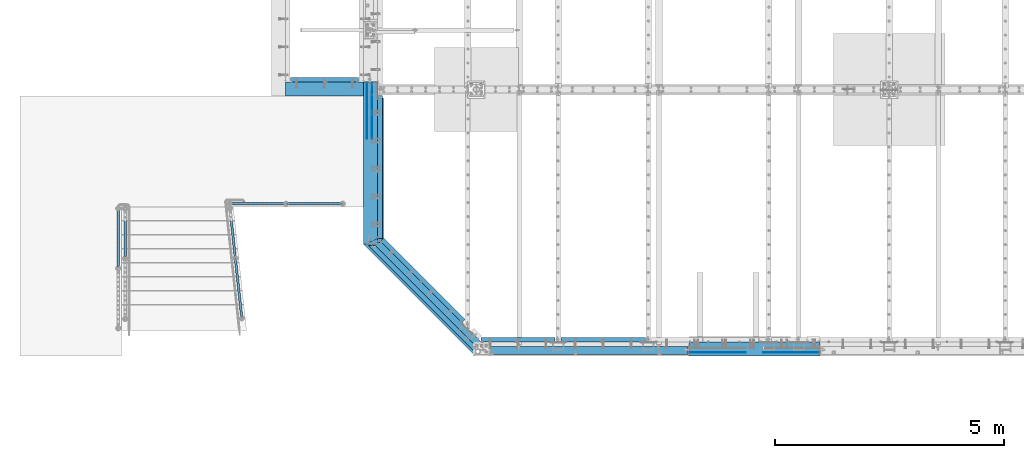
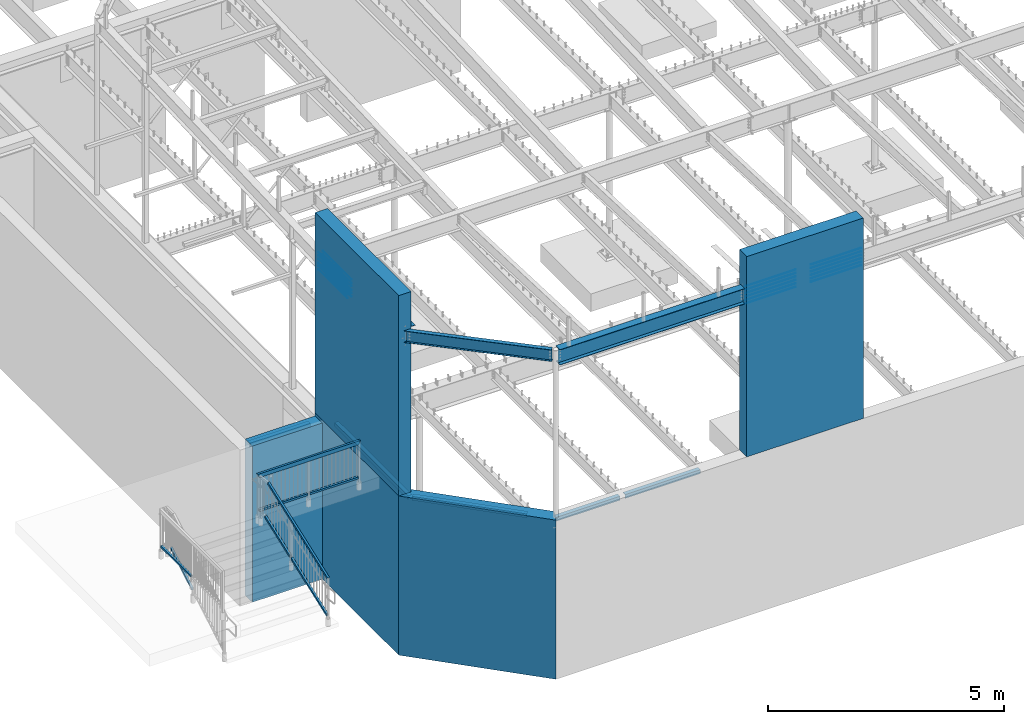
# One storey, part 309 of 975: 41 beams, 4 members.
"""IFC2X3 building model written with IfcOpenShell, lengths in millimetres."""

from ifc_helpers import new_model, si_unit, frame, origin_with_axes, place, context, subcontext, project, spatial, faceted_brep, material, type_object, element, save


model = new_model("IFC2X3")

# Units and contexts
model_context = context("Model", 3, precision=1e-05, world=origin_with_axes())
body_context = subcontext(model_context, "Body", "Model", "MODEL_VIEW")
ifc_project = project(units=[si_unit("LENGTHUNIT", "METRE", prefix="MILLI"), si_unit("AREAUNIT", "SQUARE_METRE"), si_unit("VOLUMEUNIT", "CUBIC_METRE"), si_unit("MASSUNIT", "GRAM", prefix="KILO"), si_unit("TIMEUNIT", "SECOND"), si_unit("PLANEANGLEUNIT", "RADIAN"), si_unit("SOLIDANGLEUNIT", "STERADIAN"), si_unit("THERMODYNAMICTEMPERATUREUNIT", "DEGREE_CELSIUS"), si_unit("LUMINOUSINTENSITYUNIT", "LUMEN")], contexts=[model_context])

# Site, building, storey
site_placement = place(None, origin_with_axes())
site = spatial("IfcSite", under=ifc_project, at=site_placement, CompositionType="ELEMENT")
building_placement = place(site_placement, origin_with_axes())
building = spatial("IfcBuilding", under=site, at=building_placement, Name="Undefined", CompositionType="ELEMENT")
storey_placement = place(building_placement, origin_with_axes())
storey = spatial("IfcBuildingStorey", under=building, at=storey_placement, Name="Undefined", CompositionType="ELEMENT", Elevation=0.0)

# Beams
ifc_material_1 = material()
beam_type_1 = type_object("IfcBeamType", Name="HSS2X2X.188_TUBES", PredefinedType="NOTDEFINED")
beam_1_placement = place(storey_placement, frame((479.425390027596, 3327.40039056696, 4229.10001248399), z_axis=(-3.3379000014861e-05, 0.999999999442921, 0.0), x_axis=(0.999999999442921, 3.33790000148717e-05, -8.99999974375122e-09)))
element("IfcBeam", 1, at=beam_1_placement, inside=storey, type_object=beam_type_1, material=ifc_material_1, Name="HANDRAIL", ObjectType="HSS2X2X.188_TUBES", context=body_context, shape_type="Brep", body=[
    faceted_brep([(-131.330281743522, 20.6374999999525, -20.6374999999862), (-131.330282156286, -20.637500000048, -20.6374999999798), (1054.09891845322, -20.6374999996206, -20.6375000001312), (1054.09891886599, 20.6375000003791, -20.6375000001376), (-131.328904438064, -20.6375000000471, 20.6375000000207), (1054.10029617145, -20.6374999996215, 20.6374999998693), (-131.3289040253, 20.6374999999525, 20.6375000000144), (1054.10029658421, 20.6375000003791, 20.6374999998629), (-131.330440663382, 25.3999999999523, -25.3999999999869), (-131.328745010186, 25.3999999999523, 25.4000000000137), (1054.10045559932, 25.4000000003798, 25.3999999998628), (1054.09875994613, 25.4000000003798, -25.4000000001379), (-131.328745518203, -25.4000000000478, 25.4000000000215), (1054.10045509131, -25.3999999996204, 25.3999999998705), (-131.330441171399, -25.4000000000469, -25.3999999999796), (1054.09875943811, -25.3999999996204, -25.4000000001297)], [[[0, 1, 2, 3]], [[1, 4, 5, 2]], [[4, 6, 7, 5]], [[6, 0, 3, 7]], [[8, 9, 10, 11]], [[9, 12, 13, 10]], [[12, 14, 15, 13]], [[14, 8, 11, 15]], [[13, 15, 11, 10], [5, 7, 3, 2]], [[14, 12, 9, 8], [6, 4, 1, 0]]]),
])
beam_2_placement = place(storey_placement, frame((-913.533792306628, 3327.43681280912, 4229.10002239251), z_axis=(2.61469999909423e-05, 0.999999999658167, 0.0), x_axis=(0.999999999658167, -2.61469999909112e-05, -7.00000017624839e-09)))
element("IfcBeam", 2, at=beam_2_placement, inside=storey, type_object=beam_type_1, material=ifc_material_1, Name="HANDRAIL", ObjectType="HSS2X2X.188_TUBES", context=body_context, shape_type="Brep", body=[
    faceted_brep([(25.400897527059, 20.6375000000089, -20.6374999999903), (25.4009170500576, -20.6374999999916, -20.637499999993), (1210.83012917405, -20.6374999995396, -20.6374999999694), (1210.83012950426, 20.6375000004609, -20.6374999999771), (25.3998894558863, -20.6375000000044, 20.6375), (1210.82904995662, -20.6374999995396, 20.6375000000248), (25.3998247226641, 20.6375000000016, 20.6374999999316), (1210.82905028684, 20.63750000046, 20.6375000000171), (25.4010547061143, 25.4000000000133, -25.400000000096), (25.3997254455859, 25.4000000000096, 25.3999999999928), (1210.82892579985, 25.4000000004608, 25.400000000016), (1210.83025406745, 25.4000000004608, -25.3999999999769), (25.3997250391686, -25.3999999999905, 25.4000000000019), (1210.82892539343, -25.3999999995394, 25.4000000000251), (25.4010533067686, -25.3999999999896, -25.399999999991), (1210.83025366103, -25.3999999995394, -25.3999999999678)], [[[0, 1, 2, 3]], [[1, 4, 5, 2]], [[4, 6, 7, 5]], [[6, 0, 3, 7]], [[8, 9, 10, 11]], [[9, 12, 13, 10]], [[12, 14, 15, 13]], [[14, 8, 11, 15]], [[13, 15, 11, 10], [5, 7, 3, 2]], [[14, 12, 9, 8], [6, 4, 1, 0]]]),
])
beam_3_placement = place(storey_placement, frame((-3343.27499858123, 1917.70035219894, 4229.10001248399), z_axis=(-0.999999999999998, 6.90000001668524e-08, 0.0), x_axis=(0.0, 1.0, 0.0)))
element("IfcBeam", 3, at=beam_3_placement, inside=storey, type_object=beam_type_1, material=ifc_material_1, Name="HANDRAIL", ObjectType="HSS2X2X.188_TUBES", context=body_context, shape_type="Brep", body=[
    faceted_brep([(25.3999997357314, 20.6374999999898, -20.6374999999998), (25.4000002641624, -20.6375000000153, -20.6374999999998), (1282.70000035021, -20.637500000109, -20.6374999999998), (1282.70000072169, 20.6374999998907, -20.6374999999998), (25.4000002641624, -20.6375000000153, 20.6374999999998), (1282.70000035021, -20.637500000109, 20.6374999999998), (25.3999997357314, 20.6374999999898, 20.6374999999998), (1282.70000072169, 20.6374999998907, 20.6374999999998), (25.4000003077635, 25.3999999999942, -25.3999999999996), (25.3999996747552, 25.3999999999905, 25.3999999999996), (1282.70000076455, 25.3999999998914, 25.4000000000001), (1282.70000076455, 25.3999999998914, -25.4000000000001), (25.4000003251349, -25.4000000000124, 25.3999999999996), (1282.70000030735, -25.4000000001088, 25.4000000000001), (25.4000003077854, -25.4000000000087, -25.3999999999996), (1282.70000030735, -25.4000000001088, -25.4000000000001)], [[[0, 1, 2, 3]], [[1, 4, 5, 2]], [[4, 6, 7, 5]], [[6, 0, 3, 7]], [[8, 9, 10, 11]], [[9, 12, 13, 10]], [[12, 14, 15, 13]], [[14, 8, 11, 15]], [[13, 15, 11, 10], [5, 7, 3, 2]], [[14, 12, 9, 8], [6, 4, 1, 0]]]),
])

# Members
member_type = type_object("IfcMemberType", Name="HSS2X2X.188_TUBES", PredefinedType="NOTDEFINED")
member_1_placement = place(storey_placement, frame((-786.90592702159, 2152.61454383, 3699.25226004186), z_axis=(-0.99424137783609, -0.107163811982336, -8.59999973377852e-08), x_axis=(-0.0925657529716952, 0.858804733737394, 0.503871025845926)))
element("IfcMember", 4, at=member_1_placement, inside=storey, type_object=member_type, material=ifc_material_1, Name="HANDRAIL", ObjectType="HSS2X2X.188_TUBES", context=body_context, shape_type="Brep", body=[
    faceted_brep([(2.55046412185675, 20.6375000000007, -20.6375000000004), (26.6275483126865, -20.6374999999948, -20.6375000000022), (1057.13372052329, -20.637499999902, -20.6374999999904), (1045.97505016764, 20.6375000000953, -20.6374999999882), (26.6275482985616, -20.6374999999989, 20.6375000000005), (1057.13372042627, -20.6374999999057, 20.6375000000122), (2.5504641077323, 20.6374999999971, 20.6375000000022), (1045.97505007061, 20.6375000000908, 20.6375000000144), (-0.227660975455819, 25.4000000000015, -25.4000000000003), (-0.227660992839446, 25.399999999996, 25.4000000000028), (1044.68751117222, 25.4000000000897, 25.4000000000148), (1044.68751129164, 25.4000000000951, -25.3999999999886), (29.4056733958746, -25.3999999999987, 25.4000000000005), (1058.42125930226, -25.399999999906, 25.4000000000124), (29.4056734132582, -25.3999999999933, -25.4000000000028), (1058.42125942168, -25.3999999999019, -25.3999999999909)], [[[0, 1, 2, 3]], [[1, 4, 5, 2]], [[4, 6, 7, 5]], [[6, 0, 3, 7]], [[8, 9, 10, 11]], [[9, 12, 13, 10]], [[12, 14, 15, 13]], [[14, 8, 11, 15]], [[13, 15, 11, 10], [5, 7, 3, 2]], [[14, 12, 9, 8], [6, 4, 1, 0]]]),
])
member_2_placement = place(storey_placement, frame((-645.364094704221, 839.420506353041, 2928.78558603361), z_axis=(-0.99424137783609, -0.107163811982336, -8.59999973377852e-08), x_axis=(-0.0925657529716952, 0.858804733737394, 0.503871025845926)))
element("IfcMember", 5, at=member_2_placement, inside=storey, type_object=member_type, material=ifc_material_1, Name="HANDRAIL", ObjectType="HSS2X2X.188_TUBES", context=body_context, shape_type="Brep", body=[
    faceted_brep([(2.55046412185675, 20.6375000000007, -20.6375000000004), (26.6275483126865, -20.6374999999948, -20.6375000000022), (1496.91121689991, -20.6374999997697, -20.6375000000742), (1472.83413271209, 20.6375000002295, -20.6375000000716), (26.6275482985616, -20.6374999999989, 20.6375000000005), (1496.91121692682, -20.6374999997643, 20.6374999999254), (2.5504641077323, 20.6374999999971, 20.6375000000022), (1472.834132739, 20.6375000002349, 20.6374999999281), (-0.227660975455819, 25.4000000000015, -25.4000000000003), (-0.227660992839446, 25.399999999996, 25.4000000000028), (1470.05600764351, 25.4000000002352, 25.3999999999284), (1470.05600761039, 25.4000000002284, -25.4000000000711), (29.4056733958746, -25.3999999999987, 25.4000000000005), (1499.68934202852, -25.3999999997636, 25.3999999999249), (29.4056734132582, -25.3999999999933, -25.4000000000028), (1499.6893419954, -25.3999999997704, -25.4000000000746)], [[[0, 1, 2, 3]], [[1, 4, 5, 2]], [[4, 6, 7, 5]], [[6, 0, 3, 7]], [[8, 9, 10, 11]], [[9, 12, 13, 10]], [[12, 14, 15, 13]], [[14, 8, 11, 15]], [[13, 15, 11, 10], [5, 7, 3, 2]], [[14, 12, 9, 8], [6, 4, 1, 0]]]),
])
member_3_placement = place(storey_placement, frame((-643.992580326379, 826.695897142253, 3907.59432681638), z_axis=(-0.99424137783609, -0.107163811982336, -8.59999973377852e-08), x_axis=(-0.0925657529716952, 0.858804733737394, 0.503871025845926)))
element("IfcMember", 6, at=member_3_placement, inside=storey, type_object=member_type, material=ifc_material_1, Name="HANDRAIL", ObjectType="HSS2X2X.188_TUBES", context=body_context, shape_type="Brep", body=[
    faceted_brep([(11.8535676793817, 20.6375000000003, -20.6374999999996), (-11.8535673581096, -20.6375000000062, -20.6375), (2483.60566882406, -20.6374999996169, -20.6375000001226), (2472.44700660959, 20.6375000003854, -20.6375000001206), (-11.8535673311985, -20.6375000000007, 20.6374999999996), (2483.60566883982, -20.6374999996106, 20.6374999998769), (11.8535677062928, 20.6375000000057, 20.6374999999999), (2472.44700662534, 20.6375000003895, 20.6374999998792), (14.5890063344486, 25.4000000000001, -25.3999999999995), (14.5890063675702, 25.4000000000069, 25.4), (2471.15946867934, 25.4000000003916, 25.3999999998792), (2471.15946865995, 25.4000000003853, -25.4000000001204), (-14.5890059862654, -25.400000000001, 25.3999999999995), (2484.89320678946, -25.3999999996104, 25.3999999998767), (-14.5890060193869, -25.4000000000078, -25.4), (2484.89320677007, -25.3999999996167, -25.4000000001228)], [[[0, 1, 2, 3]], [[1, 4, 5, 2]], [[4, 6, 7, 5]], [[6, 0, 3, 7]], [[8, 9, 10, 11]], [[9, 12, 13, 10]], [[12, 14, 15, 13]], [[14, 8, 11, 15]], [[13, 15, 11, 10], [5, 7, 3, 2]], [[14, 12, 9, 8], [6, 4, 1, 0]]]),
])
member_4_placement = place(storey_placement, frame((-3190.87499858123, 2146.3986890032, 3699.2522600453), z_axis=(-0.999999999999998, 6.90000001668524e-08, 0.0), x_axis=(0.0, 0.863778900717086, 0.503871025834967)))
element("IfcMember", 7, at=member_4_placement, inside=storey, type_object=member_type, material=ifc_material_1, Name="HANDRAIL", ObjectType="HSS2X2X.188_TUBES", context=body_context, shape_type="Brep", body=[
    faceted_brep([(2.55046412185675, 20.6375000000007, -20.6375000000004), (26.6275483126865, -20.6374999999948, -20.6375000000022), (1057.13364598179, -20.6375000000303, -20.6374999999998), (1045.97498376597, 20.6374999999698, -20.6374999999998), (26.6275482985616, -20.6374999999989, 20.6375000000005), (1057.13364598179, -20.6375000000303, 20.6374999999998), (2.5504641077323, 20.6374999999971, 20.6375000000022), (1045.97498376597, 20.6374999999698, 20.6374999999998), (-0.227660975455819, 25.4000000000015, -25.4000000000003), (-0.227660992839446, 25.399999999996, 25.4000000000028), (1044.68744581799, 25.3999999999701, 25.4000000000001), (1044.68744581799, 25.3999999999701, -25.4000000000001), (29.4056733958746, -25.3999999999987, 25.4000000000005), (1058.42118392977, -25.4000000000306, 25.4000000000001), (29.4056734132582, -25.3999999999933, -25.4000000000028), (1058.42118392977, -25.4000000000306, -25.4000000000001)], [[[0, 1, 2, 3]], [[1, 4, 5, 2]], [[4, 6, 7, 5]], [[6, 0, 3, 7]], [[8, 9, 10, 11]], [[9, 12, 13, 10]], [[12, 14, 15, 13]], [[14, 8, 11, 15]], [[13, 15, 11, 10], [5, 7, 3, 2]], [[14, 12, 9, 8], [6, 4, 1, 0]]]),
])

# Beams
beam_type_2 = type_object("IfcBeamType", Name="HSS2X4X.188_TUBES", PredefinedType="NOTDEFINED")
beam_4_placement = place(storey_placement, frame((-913.533792537803, 3327.43681221003, 5130.80000243843), z_axis=(0.0, 0.0, 1.0), x_axis=(1.0, 0.0, 0.0)))
element("IfcBeam", 8, at=beam_4_placement, inside=storey, type_object=beam_type_2, material=ifc_material_1, Name="HANDRAIL", ObjectType="HSS2X4X.188_TUBES", context=body_context, shape_type="Brep", body=[
    faceted_brep([(23.019142744539, 20.6374999999962, -46.0374999999985), (23.0191427445435, -20.6375000000035, -46.0374999999985), (2449.44003539194, -20.6375000003882, -46.037499999793), (2449.44003539193, 20.6374999996115, -46.037499999793), (-23.0183653307359, -20.6374999999962, 46.0374999999976), (2495.47754172868, -20.6375000003954, 46.0375000002105), (-23.0183653307405, 20.6375000000039, 46.0374999999976), (2495.47754172867, 20.6374999996046, 46.0375000002105), (25.4003931622252, 25.399999999996, -50.7999999999984), (-25.3996157484279, 25.4000000000046, 50.7999999999984), (2497.85879205644, 25.399999999604, 50.8000000002112), (2447.05878506417, 25.3999999996117, -50.7999999997937), (-25.3996157484222, -25.399999999996, 50.7999999999984), (2497.85879205644, -25.4000000003962, 50.8000000002112), (25.4003931622309, -25.4000000000037, -50.7999999999984), (2447.05878506417, -25.400000000388, -50.7999999997937)], [[[0, 1, 2, 3]], [[1, 4, 5, 2]], [[4, 6, 7, 5]], [[6, 0, 3, 7]], [[8, 9, 10, 11]], [[9, 12, 13, 10]], [[12, 14, 15, 13]], [[14, 8, 11, 15]], [[13, 15, 11, 10], [5, 7, 3, 2]], [[14, 12, 9, 8], [6, 4, 1, 0]]]),
])
ifc_material_2 = material(Name="CONCRETE/5000")
beam_type_3 = type_object("IfcBeamType", PredefinedType="NOTDEFINED")
beam_5_placement = place(storey_placement, frame((304.800030162501, 5829.3, 2019.3), z_axis=(0.0, 0.0, 1.0), x_axis=(1.0, 0.0, 0.0)))
element("IfcBeam", 9, at=beam_5_placement, inside=storey, type_object=beam_type_3, material=ifc_material_2, Name="WALL", context=body_context, shape_type="Brep", body=[
    faceted_brep([(0.0, 152.4, -2019.3), (0.0, 152.4, 2019.3), (1711.3249698375, 152.4, 2019.3), (1711.3249698375, 152.4, -2019.3), (0.0, -152.4, 2019.3), (1711.3249698375, -152.4, 2019.3), (0.0, -152.4, -2019.3), (1711.3249698375, -152.4, -2019.3)], [[[0, 1, 2, 3]], [[1, 4, 5, 2]], [[4, 6, 7, 5]], [[6, 0, 3, 7]], [[5, 7, 3, 2]], [[6, 4, 1, 0]]]),
])
ifc_material_3 = material(Name="STEEL/A36")
beam_type_4 = type_object("IfcBeamType", Name="L4X4X5/16", PredefinedType="NOTDEFINED")
beam_6_placement = place(storey_placement, frame((2371.72481651674, 2564.65266968717, 3886.2), z_axis=(1.0, 0.0, 0.0), x_axis=(0.0, 1.0, 0.0)))
element("IfcBeam", 10, at=beam_6_placement, inside=storey, type_object=beam_type_4, material=ifc_material_3, Name="LEDGER_ANGLE", ObjectType="L4X4X5/16", context=body_context, shape_type="Brep", body=[
    faceted_brep([(-1.90993887372315e-11, 50.8000000000002, -50.8), (2.00088834390044e-11, 50.8000000000002, 50.8), (3128.1223273127, 50.8000000000002, 50.7999999994709), (3128.12232731269, 50.8000000000002, -50.8000000005291), (2.00088834390044e-11, 42.8625000000002, 50.8), (3128.1223273127, 42.8625000000002, 50.7999999994709), (-1.63709046319127e-11, 42.8625000000002, -42.8625), (3128.12232731269, 42.8625000000002, -42.8625000005295), (-1.63709046319127e-11, -50.8000000000002, -42.8625), (3128.12232731269, -50.8000000000002, -42.8625000005295), (-1.90993887372315e-11, -50.8000000000002, -50.8), (3128.12232731269, -50.8000000000002, -50.8000000005291)], [[[0, 1, 2, 3]], [[1, 4, 5, 2]], [[4, 6, 7, 5]], [[6, 8, 9, 7]], [[8, 10, 11, 9]], [[10, 0, 3, 11]], [[5, 7, 9, 11, 3, 2]], [[10, 8, 6, 4, 1, 0]]]),
])
beam_7_placement = place(storey_placement, frame((2416.62610021754, 2540.79343794826, 3886.2), z_axis=(0.0, 0.0, -1.0), x_axis=(0.707106781186513, -0.707106781186582, 3.1377567211166e-14)))
element("IfcBeam", 11, at=beam_7_placement, inside=storey, type_object=beam_type_4, material=ifc_material_3, Name="LEDGER_ANGLE", ObjectType="L4X4X5/16", context=body_context, shape_type="Brep", body=[
    faceted_brep([(-1.90993887372315e-11, 50.8000000000002, -50.8), (2.00088834390044e-11, 50.8000000000002, 50.8), (2514.69244094131, 50.8000000000084, 50.8000000000002), (2514.69244094131, 50.8000000000084, -50.8000000000002), (2.00088834390044e-11, 42.8625000000002, 50.8), (2514.69244094131, 42.8625000000075, 50.8000000000002), (-1.63709046319127e-11, 42.8625000000002, -42.8625), (2514.69244094131, 42.8625000000075, -42.8625000000002), (-1.63709046319127e-11, -50.8000000000002, -42.8625), (2514.69244094131, -50.8000000000084, -42.8625000000002), (-1.90993887372315e-11, -50.8000000000002, -50.8), (2514.69244094131, -50.8000000000084, -50.8000000000002)], [[[0, 1, 2, 3]], [[1, 4, 5, 2]], [[4, 6, 7, 5]], [[6, 8, 9, 7]], [[8, 10, 11, 9]], [[10, 0, 3, 11]], [[5, 7, 9, 11, 3, 2]], [[10, 8, 6, 4, 1, 0]]]),
])
beam_8_placement = place(storey_placement, frame((6323.54172920507, 355.6, 3886.2), z_axis=(0.0, 0.0, -1.0), x_axis=(1.0, 0.0, 0.0)))
element("IfcBeam", 12, at=beam_8_placement, inside=storey, type_object=beam_type_4, material=ifc_material_3, Name="LEDGER_ANGLE", ObjectType="L4X4X5/16", context=body_context, shape_type="Brep", body=[
    faceted_brep([(-1.90993887372315e-11, 50.8000000000002, -50.8), (2.00088834390044e-11, 50.8000000000002, 50.8), (1842.55827079493, 50.8, 50.8000000000002), (1842.55827079493, 50.8, -50.8000000000002), (2.00088834390044e-11, 42.8625000000002, 50.8), (1842.55827079493, 42.8625, 50.8000000000002), (-1.63709046319127e-11, 42.8625000000002, -42.8625), (1842.55827079493, 42.8625, -42.8625000000002), (-1.63709046319127e-11, -50.8000000000002, -42.8625), (1842.55827079493, -50.8, -42.8625000000002), (-1.90993887372315e-11, -50.8000000000002, -50.8), (1842.55827079493, -50.8, -50.8000000000002)], [[[0, 1, 2, 3]], [[1, 4, 5, 2]], [[4, 6, 7, 5]], [[6, 8, 9, 7]], [[8, 10, 11, 9]], [[10, 0, 3, 11]], [[5, 7, 9, 11, 3, 2]], [[10, 8, 6, 4, 1, 0]]]),
])
beam_9_placement = place(storey_placement, frame((4580.77748893617, 355.6, 3886.2), z_axis=(0.0, 0.0, -1.0), x_axis=(1.0, 0.0, 0.0)))
element("IfcBeam", 13, at=beam_9_placement, inside=storey, type_object=beam_type_4, material=ifc_material_3, Name="LEDGER_ANGLE", ObjectType="L4X4X5/16", context=body_context, shape_type="Brep", body=[
    faceted_brep([(-1.90993887372315e-11, 50.8000000000002, -50.8), (2.00088834390044e-11, 50.8000000000002, 50.8), (1615.7642402689, 50.8, 50.8000000000002), (1615.7642402689, 50.8, -50.8000000000002), (2.00088834390044e-11, 42.8625000000002, 50.8), (1615.7642402689, 42.8625, 50.8000000000002), (-1.63709046319127e-11, 42.8625000000002, -42.8625), (1615.7642402689, 42.8625, -42.8625000000002), (-1.63709046319127e-11, -50.8000000000002, -42.8625), (1615.7642402689, -50.8, -42.8625000000002), (-1.90993887372315e-11, -50.8000000000002, -50.8), (1615.7642402689, -50.8, -50.8000000000002)], [[[0, 1, 2, 3]], [[1, 4, 5, 2]], [[4, 6, 7, 5]], [[6, 8, 9, 7]], [[8, 10, 11, 9]], [[10, 0, 3, 11]], [[5, 7, 9, 11, 3, 2]], [[10, 8, 6, 4, 1, 0]]]),
])
beam_10_placement = place(storey_placement, frame((1901.82501000529, 6032.4999997141, 3835.4), z_axis=(0.0, 1.0, 0.0), x_axis=(-0.999999999999998, 6.90000001668524e-08, 0.0)))
element("IfcBeam", 14, at=beam_10_placement, inside=storey, type_object=beam_type_4, material=ifc_material_3, Name="LEDGER_ANGLE", ObjectType="L4X4X5/16", context=body_context, shape_type="Brep", body=[
    faceted_brep([(-1.90993887372315e-11, 50.8000000000002, -50.8), (2.00088834390044e-11, 50.8000000000002, 50.8), (1482.7250193691, 50.8000000000002, 50.8000000000002), (1482.7250193691, 50.8000000000002, -50.8000000000002), (2.00088834390044e-11, 42.8625000000002, 50.8), (1482.7250193691, 42.8625000000002, 50.8000000000002), (-1.63709046319127e-11, 42.8625000000002, -42.8625), (1482.7250193691, 42.8625000000002, -42.8625000000002), (-1.63709046319127e-11, -50.8000000000002, -42.8625), (1482.7250193691, -50.8000000000002, -42.8625000000002), (-1.90993887372315e-11, -50.8000000000002, -50.8), (1482.7250193691, -50.8000000000002, -50.8000000000002)], [[[0, 1, 2, 3]], [[1, 4, 5, 2]], [[4, 6, 7, 5]], [[6, 8, 9, 7]], [[8, 10, 11, 9]], [[10, 0, 3, 11]], [[5, 7, 9, 11, 3, 2]], [[10, 8, 6, 4, 1, 0]]]),
])
beam_type_5 = type_object("IfcBeamType", Name="L5X3X5/16", PredefinedType="NOTDEFINED")
beam_11_placement = place(storey_placement, frame((2384.42480933648, 2478.17854632537, 8322.72808824782), z_axis=(1.0, 0.0, 0.0), x_axis=(8.29999999712945e-08, 0.999229437528133, -0.0392496009814648)))
element("IfcBeam", 15, at=beam_11_placement, inside=storey, type_object=beam_type_5, material=ifc_material_3, Name="LEDGER_ANGLE", ObjectType="L5X3X5/16", context=body_context, shape_type="Brep", body=[
    faceted_brep([(5.0931703299284e-11, 38.0999999999999, -63.5000000000255), (-4.72937244921923e-11, 38.0999999999999, 63.5000000000182), (3155.20695954853, 38.100000001954, 63.5000000001041), (3155.2069595485, 38.1000000020413, -63.4999999998963), (-3.63797880709171e-12, 30.1625000000404, 63.4999999999909), (3155.20695954854, 30.1625000019558, 63.5000000001032), (3.41060513164848e-12, 30.1624999999367, -55.5625000000091), (3155.20695954851, 30.1625000020376, -55.5624999998972), (2.27373675443232e-12, -38.1000000000313, -55.5624999999873), (3155.20695954852, -38.0999999979467, -55.5624999999031), (5.0931703299284e-11, -38.0999999999999, -63.5000000000255), (3155.20695954852, -38.0999999979413, -63.4999999999031)], [[[0, 1, 2, 3]], [[1, 4, 5, 2]], [[4, 6, 7, 5]], [[6, 8, 9, 7]], [[8, 10, 11, 9]], [[10, 0, 3, 11]], [[5, 7, 9, 11, 3, 2]], [[10, 8, 6, 4, 1, 0]]]),
])
ifc_material_4 = material(Name="STEEL/A496")
beam_type_6 = type_object("IfcBeamType", Name="#6 DBA", PredefinedType="NOTDEFINED")
for number, where, z_axis, x_axis, name in (
    (16, (11953.8750019337, 76.2000016252808, 8389.9474310055), (0.0, 1.0, 0.0), (-0.999999999999998, 6.90000001668524e-08, 0.0), "ROD"),
    (17, (11953.8750019337, 76.2000016074719, 8301.04744312985), (0.0, 1.0, 0.0), (-0.999999999999998, 6.90000001668524e-08, 0.0), "ROD"),
    (18, (11953.8750019337, 76.2000015896593, 8212.14745525419), (0.0, 1.0, 0.0), (-0.999999999999998, 6.90000001668524e-08, 0.0), "ROD"),
    (19, (11953.8750019337, 76.2000015718503, 8123.24746737853), (0.0, 1.0, 0.0), (-0.999999999999998, 6.90000001668524e-08, 0.0), "ROD"),
    (20, (11953.8750019337, 76.2000015540377, 8034.34747950287), (0.0, 1.0, 0.0), (-0.999999999999998, 6.90000001668524e-08, 0.0), "ROD"),
    (21, (11953.8750019337, 76.2000016430934, 8478.84741888116), (0.0, 1.0, 0.0), (-0.999999999999998, 6.90000001668524e-08, 0.0), "ROD"),
    (22, (9137.65001522342, 76.1996154709207, 8389.9475019974), (0.0, -1.0, 0.0), (1.0, 0.0, 0.0), "ROD"),
    (23, (9137.65001522342, 76.1996154887296, 8301.04751412175), (0.0, -1.0, 0.0), (1.0, 0.0, 0.0), "ROD"),
    (24, (9137.65001522342, 76.1996155065422, 8212.14752624609), (0.0, -1.0, 0.0), (1.0, 0.0, 0.0), "ROD"),
    (25, (9137.65001522342, 76.1996155243511, 8123.24753837043), (0.0, -1.0, 0.0), (1.0, 0.0, 0.0), "ROD"),
    (26, (9137.65001522342, 76.1996155421637, 8034.34755049477), (0.0, -1.0, 0.0), (1.0, 0.0, 0.0), "ROD"),
    (27, (9137.66990048869, 76.1996154514576, 8478.84748987306), (0.0, -1.0, 0.0), (1.0, 0.0, 0.0), "ROD"),
    (28, (2193.92509957262, 5962.61467815266, 7900.90884247343), (1.0, 0.0, 0.0), (0.0, -1.0, 0.0), "ROD"),
    (29, (2092.32509957261, 5962.61467774654, 7900.90884245726), (1.0, 0.0, 0.0), (0.0, -1.0, 0.0), "ROD"),
    (30, (2193.92509955866, 5962.56824863497, 7977.10883034909), (1.0, 0.0, 0.0), (0.0, -1.0, 0.0), "ROD"),
    (31, (2092.32509955866, 5962.56824822885, 7977.10883033292), (1.0, 0.0, 0.0), (0.0, -1.0, 0.0), "ROD"),
    (32, (2193.9250995447, 5962.52181911728, 8078.70881822475), (1.0, 0.0, 0.0), (0.0, -1.0, 0.0), "ROD"),
    (33, (2092.3250995447, 5962.52181871116, 8078.70881820857), (1.0, 0.0, 0.0), (0.0, -1.0, 0.0), "ROD"),
    (34, (2193.92509953075, 5962.47538959958, 8167.6088061004), (1.0, 0.0, 0.0), (0.0, -1.0, 0.0), "ROD"),
    (35, (2092.32509953074, 5962.47538919346, 8167.60880608423), (1.0, 0.0, 0.0), (0.0, -1.0, 0.0), "ROD"),
    (36, (2193.92509951679, 5962.42896008189, 8256.50879397606), (1.0, 0.0, 0.0), (0.0, -1.0, 0.0), "ROD"),
    (37, (2092.32509951678, 5962.42895967577, 8256.50879395989), (1.0, 0.0, 0.0), (0.0, -1.0, 0.0), "ROD"),
    (38, (2193.92509958658, 5962.66110767035, 7812.00885459777), (1.0, 0.0, 0.0), (0.0, -1.0, 0.0), "ROD"),
    (39, (2092.32509958657, 5962.66110726424, 7812.0088545816), (1.0, 0.0, 0.0), (0.0, -1.0, 0.0), "ROD"),
):
    element("IfcBeam", number, at=place(storey_placement, frame(where, z_axis=z_axis, x_axis=x_axis)), inside=storey, type_object=beam_type_6, material=ifc_material_4, Name=name, ObjectType="#6 DBA", context=body_context, shape_type="Brep", body=[
        faceted_brep([(0.0, -6.34999999998763, -3.63797880709171e-12), (0.0, -4.49012806052269, -4.49012806054634), (1219.19983372321, -4.49012806053543, -4.49012805836537), (1219.19983372321, -6.35000000000036, 2.16823536902666e-09), (0.0, 7.27595761418343e-12, -6.35000000000764), (1219.19983372321, 0.0, -6.34999999783395), (0.0, 4.49012806053724, -4.49012806053906), (1219.19983372321, 4.49012806053543, -4.49012805836537), (0.0, 6.34999999999491, 5.45696821063757e-12), (1219.19983372321, 6.35000000000036, 2.16823536902666e-09), (0.0, 4.49012806052633, 4.49012806054634), (1219.19983372321, 4.49012806053543, 4.49012806270184), (0.0, 0.0, 6.35000000000764), (1219.19983372321, 0.0, 6.35000000216678), (0.0, -4.49012806053361, 4.49012806053543), (1219.19983372321, -4.49012806053543, 4.49012806270184)], [[[0, 1, 2, 3]], [[1, 4, 5, 2]], [[4, 6, 7, 5]], [[6, 8, 9, 7]], [[8, 10, 11, 9]], [[10, 12, 13, 11]], [[12, 14, 15, 13]], [[14, 0, 3, 15]], [[5, 7, 9, 11, 13, 15, 3, 2]], [[14, 12, 10, 8, 6, 4, 1, 0]]]),
    ])
ifc_material_5 = material(Name="STEEL/A992")
beam_type_7 = type_object("IfcBeamType", Name="W12X14", PredefinedType="NOTDEFINED")
beam_12_placement = place(storey_placement, frame((2171.59715398026, 2435.32802966755, 8212.20010278498), z_axis=(0.0203719721326688, -0.0203719731326687, -0.999584896575627), x_axis=(0.706813230740279, -0.706813286740279, 0.0288103199894136)))
element("IfcBeam", 40, at=beam_12_placement, inside=storey, type_object=beam_type_7, material=ifc_material_5, Name="BEAM", ObjectType="W12X14", context=body_context, shape_type="Brep", body=[
    faceted_brep([(86.063944295452, -50.8000000000156, -150.812499999987), (-15.578247806178, 50.8000000000116, -150.812499999942), (3221.88577148278, 50.799999999696, -150.81249999903), (3221.88577148114, -50.8000000003212, -150.812499999103), (85.8809227934296, -50.8000000000161, -144.462499999987), (37.4420656199967, -2.38125000000309, -144.462499999969), (29.11458727798, -2.381250000004, 144.462499999984), (77.5534444514128, -50.800000000017, 144.462499999962), (77.3704229493902, -50.8000000000175, 150.812499999962), (-24.2717691522397, 50.8000000000093, 150.812500000006), (-24.0887476502171, 50.8000000000097, 144.462500000007), (24.3501095232156, 2.38124999999718, 144.462499999986), (32.6775878652328, 2.381249999999, -144.462499999963), (-15.7612693082003, 50.8000000000116, -144.462499999945), (3221.88577147987, -50.8000000003212, -144.462499999103), (3221.88577148066, -2.38125000031278, -144.46249999907), (3221.88577142298, -2.38125000031505, 144.462500000885), (3221.8857714222, -50.8000000003231, 144.46250000085), (3221.88577142093, -50.8000000003231, 150.812500000849), (3221.88577142257, 50.7999999996941, 150.812500000921), (3221.88577142384, 50.7999999996941, 144.462500000923), (3221.88577142306, 2.38124999968522, 144.462500000888), (3221.88577148073, 2.38124999968704, -144.462499999066), (3221.88577148151, 50.799999999696, -144.46249999903)], [[[0, 1, 2, 3]], [[0, 4, 5, 6, 7, 8, 9, 10, 11, 12, 13, 1]], [[5, 4, 14, 15]], [[6, 5, 15, 16]], [[7, 6, 16, 17]], [[8, 7, 17, 18]], [[9, 8, 18, 19]], [[10, 9, 19, 20]], [[11, 10, 20, 21]], [[12, 11, 21, 22]], [[13, 12, 22, 23]], [[1, 13, 23, 2]], [[22, 21, 20, 19, 18, 17, 16, 15, 14, 3, 2, 23]], [[4, 0, 3, 14]]]),
])
beam_type_8 = type_object("IfcBeamType", Name="W16X36", PredefinedType="NOTDEFINED")
beam_13_placement = place(storey_placement, frame((4505.325, 127.0, 8256.5875), z_axis=(0.0, 0.0, 1.0), x_axis=(1.0, 0.0, 0.0)))
element("IfcBeam", 41, at=beam_13_placement, inside=storey, type_object=beam_type_8, material=ifc_material_5, Name="BEAM", ObjectType="W16X36", context=body_context, shape_type="Brep", body=[
    faceted_brep([(69.8500073787391, -88.9000000000005, -201.6125), (69.8499926212626, 88.9000000000001, -201.6125), (4587.87500099305, 88.8999999999851, -201.6125), (4587.87501575052, -88.9000000000155, -201.6125), (69.8500073787391, -88.9000000000005, -190.5), (69.8500003294084, -3.96875000000026, -190.5), (69.8500003294084, -3.96875000000026, 190.5), (69.8500073787391, -88.9000000000005, 190.5), (69.8500073787391, -88.9000000000005, 201.612499999999), (69.8499926212626, 88.9000000000001, 201.612499999999), (69.8499926212626, 88.9000000000001, 190.5), (69.8499996705923, 3.96874999999977, 190.5), (69.8499996705923, 3.96874999999977, -190.5), (69.8499926212626, 88.9000000000001, -190.5), (4587.87501575052, -88.9000000000155, -190.5), (4587.87500870119, -3.96875000001523, -190.5), (4587.87500870119, -3.96875000001523, 190.5), (4587.87501575052, -88.9000000000155, 190.5), (4587.87501575052, -88.9000000000155, 201.612499999999), (4587.87500099305, 88.8999999999851, 201.612499999999), (4587.87500099305, 88.8999999999851, 190.5), (4587.87500804238, 3.96874999998479, 190.5), (4587.87500804238, 3.96874999998479, -190.5), (4587.87500099305, 88.8999999999851, -190.5)], [[[0, 1, 2, 3]], [[0, 4, 5, 6, 7, 8, 9, 10, 11, 12, 13, 1]], [[5, 4, 14, 15]], [[6, 5, 15, 16]], [[7, 6, 16, 17]], [[8, 7, 17, 18]], [[9, 8, 18, 19]], [[10, 9, 19, 20]], [[11, 10, 20, 21]], [[12, 11, 21, 22]], [[13, 12, 22, 23]], [[1, 13, 23, 2]], [[22, 21, 20, 19, 18, 17, 16, 15, 14, 3, 2, 23]], [[4, 0, 3, 14]]]),
])
beam_type_9 = type_object("IfcBeamType", PredefinedType="NOTDEFINED")
beam_14_placement = place(storey_placement, frame((9118.60001258816, 152.400236907677, 6705.6), z_axis=(0.0, 0.0, 1.0), x_axis=(1.0, 0.0, 0.0)))
element("IfcBeam", 42, at=beam_14_placement, inside=storey, type_object=beam_type_9, material=ifc_material_2, Name="WALL", context=body_context, shape_type="Brep", body=[
    faceted_brep([(0.0, 152.400000000001, -2590.8), (0.0, 152.400000000001, 2590.8), (2854.32499871156, 152.399999999991, 2590.8), (2854.32499871156, 152.399999999991, -2590.8), (0.0, -152.400000000001, 2590.8), (2854.32499871141, -152.40000000001, 2590.8), (0.0, -152.400000000001, -2590.8), (2854.32499871141, -152.40000000001, -2590.8)], [[[0, 1, 2, 3]], [[1, 4, 5, 2]], [[4, 6, 7, 5]], [[6, 0, 3, 7]], [[5, 7, 3, 2]], [[6, 4, 1, 0]]]),
])
beam_15_placement = place(storey_placement, frame((2168.52510012957, 5981.70039468177, 6705.6), z_axis=(0.0, 0.0, 1.0), x_axis=(0.0, -1.0, 0.0)))
element("IfcBeam", 43, at=beam_15_placement, inside=storey, type_object=beam_type_9, material=ifc_material_2, Name="WALL", context=body_context, shape_type="Brep", body=[
    faceted_brep([(0.0, 152.400000000001, -2590.8), (0.0, 152.400000000001, 2590.8), (3543.30001676394, 152.399999999888, 2590.8), (3543.30001676394, 152.399999999888, -2590.8), (0.0, -152.400000000001, 2590.8), (3543.30001676407, -152.400000000113, 2590.8), (0.0, -152.400000000001, -2590.8), (3543.30001676407, -152.400000000113, -2590.8)], [[[0, 1, 2, 3]], [[1, 4, 5, 2]], [[4, 6, 7, 5]], [[6, 0, 3, 7]], [[5, 7, 3, 2]], [[6, 4, 1, 0]]]),
])
beam_type_10 = type_object("IfcBeamType", PredefinedType="NOTDEFINED")
beam_16_placement = place(storey_placement, frame((2168.52510012957, 5981.70039468177, 2057.4), z_axis=(0.0, 0.0, 1.0), x_axis=(0.0, -1.0, 0.0)))
element("IfcBeam", 44, at=beam_16_placement, inside=storey, type_object=beam_type_10, material=ifc_material_2, Name="WALL", context=body_context, shape_type="Brep", body=[
    faceted_brep([(0.0, 152.399999999998, -2057.4), (0.0, 152.399999999998, 2057.4), (3417.0477093769, 152.399999999892, 2057.4), (3417.0477093769, 152.399999999892, -2057.4), (-4.33680868994202e-19, -152.400000000009, 2057.4), (3543.3000180535, -152.400000000113, 2057.4), (-4.33680868994202e-19, -152.400000000009, -2057.4), (3543.3000180535, -152.400000000113, -2057.4)], [[[0, 1, 2, 3]], [[1, 4, 5, 2]], [[4, 6, 7, 5]], [[6, 0, 3, 7]], [[5, 7, 3, 2]], [[6, 4, 1, 0]]]),
])
beam_17_placement = place(storey_placement, frame((2123.88787814033, 2546.16346407783, 2057.4), z_axis=(0.0, 0.0, 1.0), x_axis=(0.707106781186513, -0.707106781186582, 3.1377567211166e-14)))
element("IfcBeam", 45, at=beam_17_placement, inside=storey, type_object=beam_type_10, material=ifc_material_2, Name="WALL", context=body_context, shape_type="Brep", body=[
    faceted_brep([(126.252310491574, 152.400000000026, -2057.4), (126.252310491574, 152.400000000026, 2057.4), (3322.16660891989, 152.400000000026, 2057.4), (3322.16660891989, 152.400000000026, -2057.4), (-4.33680868994202e-19, -152.400000000009, 2057.4), (3448.41890291847, -152.400000000025, 2057.4), (-4.33680868994202e-19, -152.400000000009, -2057.4), (3448.41890291847, -152.400000000025, -2057.4)], [[[0, 1, 2, 3]], [[1, 4, 5, 2]], [[4, 6, 7, 5]], [[6, 0, 3, 7]], [[5, 7, 3, 2]], [[6, 4, 1, 0]]]),
])

save(model, "model.ifc")
